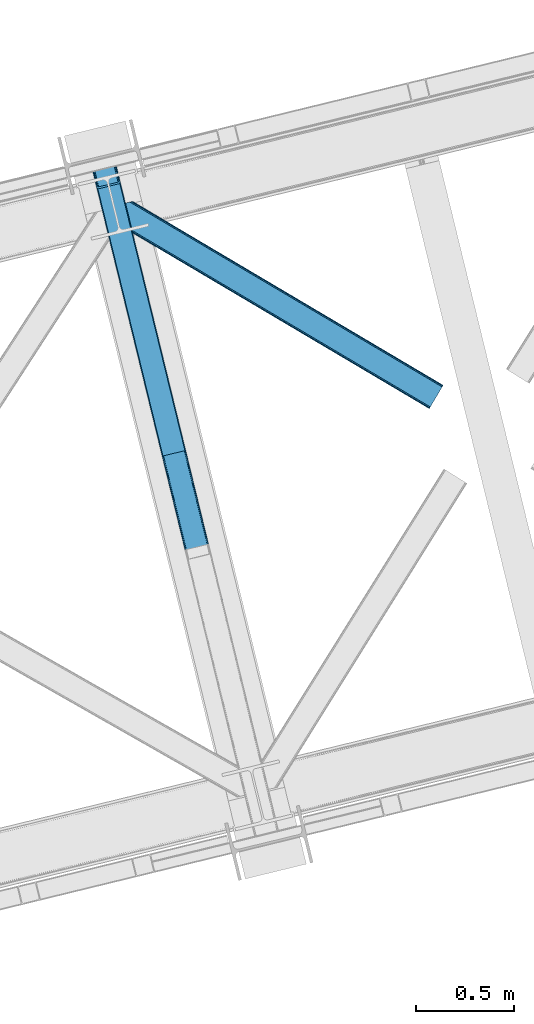
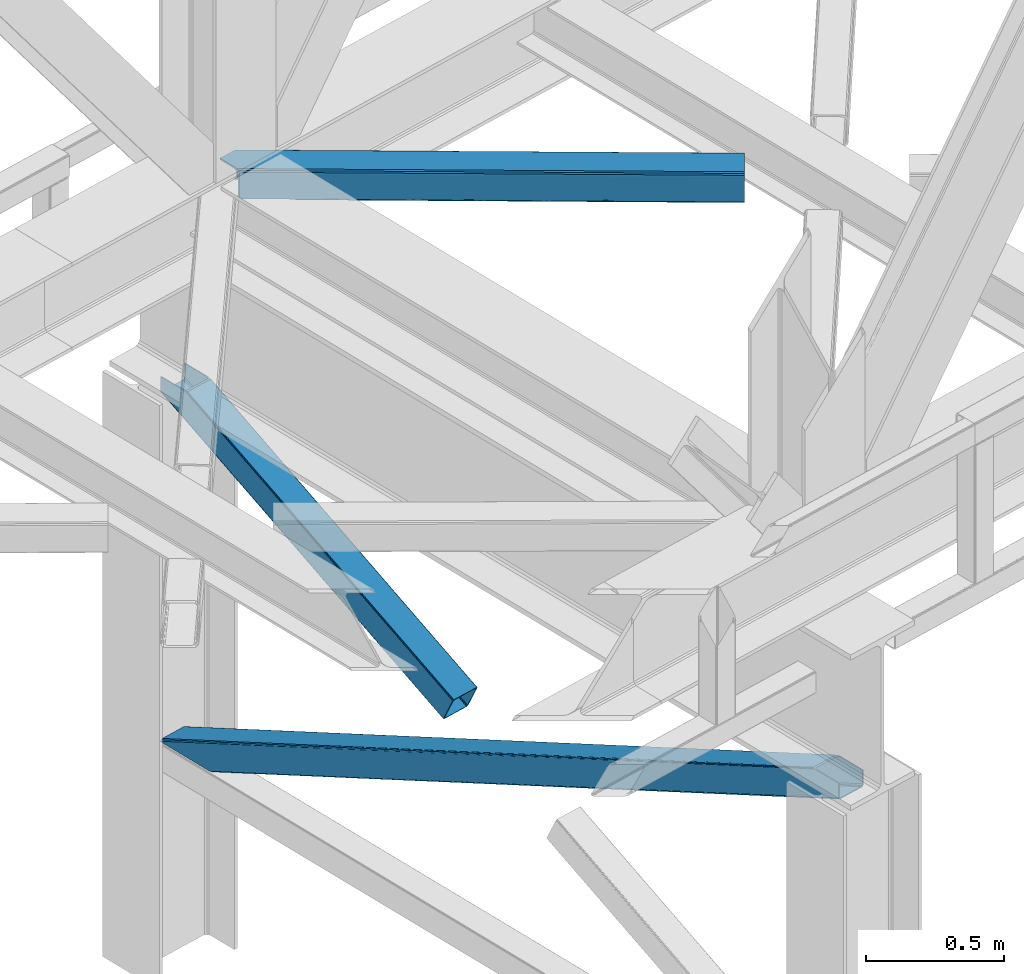
# One storey, part 57 of 92: 3 members.
"""IFC4 building model written with IfcOpenShell, lengths in millimetres."""

from ifc_helpers import new_model, entity, si_unit, converted_unit, derived_unit, direction, frame, origin, place, context, subcontext, project, spatial, triangles, polygons, type_object, element, save


model = new_model("IFC4")

# Units and contexts
model_context = context("Model", 3, precision=0.01, world=origin(), true_north=direction((6.12303176911189e-17, 1.0)))
plan_context = context("Plan", 3, precision=0.01, world=origin(), true_north=direction((6.12303176911189e-17, 1.0)))
body_context = subcontext(model_context, "Body", "Model", "MODEL_VIEW")
ifc_project = project(units=[si_unit("LENGTHUNIT", "METRE", prefix="MILLI"), si_unit("AREAUNIT", "SQUARE_METRE"), si_unit("VOLUMEUNIT", "CUBIC_METRE"), converted_unit("PLANEANGLEUNIT", "DEGREE", entity("IfcRatioMeasure", 0.0174532925199433), si_unit("PLANEANGLEUNIT", "RADIAN"), dimensions=[0, 0, 0, 0, 0, 0, 0]), si_unit("MASSUNIT", "GRAM", prefix="KILO"), derived_unit("MASSDENSITYUNIT", [(si_unit("MASSUNIT", "GRAM", prefix="KILO"), 1), (si_unit("LENGTHUNIT", "METRE"), -3)]), derived_unit("MOMENTOFINERTIAUNIT", [(si_unit("LENGTHUNIT", "METRE"), 4)]), si_unit("TIMEUNIT", "SECOND"), si_unit("FREQUENCYUNIT", "HERTZ"), si_unit("THERMODYNAMICTEMPERATUREUNIT", "DEGREE_CELSIUS"), derived_unit("THERMALTRANSMITTANCEUNIT", [(si_unit("MASSUNIT", "GRAM", prefix="KILO"), 1), (si_unit("THERMODYNAMICTEMPERATUREUNIT", "KELVIN"), -1), (si_unit("TIMEUNIT", "SECOND"), -3)]), derived_unit("VOLUMETRICFLOWRATEUNIT", [(si_unit("LENGTHUNIT", "METRE"), 3), (si_unit("TIMEUNIT", "SECOND"), -1)]), derived_unit("MASSFLOWRATEUNIT", [(si_unit("MASSUNIT", "GRAM", prefix="KILO"), 1), (si_unit("TIMEUNIT", "SECOND"), -1)]), derived_unit("ROTATIONALFREQUENCYUNIT", [(si_unit("TIMEUNIT", "SECOND"), -1)]), si_unit("ELECTRICCURRENTUNIT", "AMPERE"), si_unit("ELECTRICVOLTAGEUNIT", "VOLT"), si_unit("POWERUNIT", "WATT"), si_unit("FORCEUNIT", "NEWTON", prefix="KILO"), si_unit("ILLUMINANCEUNIT", "LUX"), si_unit("LUMINOUSFLUXUNIT", "LUMEN"), si_unit("LUMINOUSINTENSITYUNIT", "CANDELA"), derived_unit("USERDEFINED", [(si_unit("MASSUNIT", "GRAM", prefix="KILO"), -1), (si_unit("LENGTHUNIT", "METRE"), -2), (si_unit("TIMEUNIT", "SECOND"), 3), (si_unit("LUMINOUSFLUXUNIT", "LUMEN"), 1)]), derived_unit("LINEARVELOCITYUNIT", [(si_unit("LENGTHUNIT", "METRE"), 1), (si_unit("TIMEUNIT", "SECOND"), -1)]), si_unit("PRESSUREUNIT", "PASCAL"), derived_unit("USERDEFINED", [(si_unit("LENGTHUNIT", "METRE"), -2), (si_unit("MASSUNIT", "GRAM", prefix="KILO"), 1), (si_unit("TIMEUNIT", "SECOND"), -2)]), derived_unit("LINEARFORCEUNIT", [(si_unit("MASSUNIT", "GRAM", prefix="KILO"), 1), (si_unit("LENGTHUNIT", "METRE"), 1), (si_unit("TIMEUNIT", "SECOND"), -2), (si_unit("LENGTHUNIT", "METRE"), -1)]), derived_unit("PLANARFORCEUNIT", [(si_unit("MASSUNIT", "GRAM", prefix="KILO"), 1), (si_unit("LENGTHUNIT", "METRE"), 1), (si_unit("TIMEUNIT", "SECOND"), -2), (si_unit("LENGTHUNIT", "METRE"), -2)])], contexts=[model_context, plan_context])

# Site, building, storey
site_placement = place(None, origin())
site = spatial("IfcSite", under=ifc_project, at=site_placement, CompositionType="ELEMENT")
building_placement = place(site_placement, origin())
building = spatial("IfcBuilding", under=site, at=building_placement, CompositionType="ELEMENT")
storey_placement = place(building_placement, frame((0.0, 0.0, 15900.0)))
storey = spatial("IfcBuildingStorey", under=building, at=storey_placement, Name="05", CompositionType="ELEMENT", Elevation=15900.0)

# Members
member_type_1 = type_object("IfcMemberType", PredefinedType="BRACE")
member_1_placement = place(storey_placement, frame((-30279.23, 12158.54, 1820.91)))
element("IfcMember", 1, at=member_1_placement, inside=storey, type_object=member_type_1, ObjectType="Steel Vertical Brace", PredefinedType="BRACE", context=body_context, shape_type="Tessellation", body=[
    polygons([(29.8135191782847, 1388.61826467864, 771.091297096984), (32.1113287327985, 1381.7631169139, 771.091297096991), (368.111452939622, 3.36089743274636, 105.060837153753), (367.211709770158, 4.48063717440627, 102.289544138114), (35.2425975620341, 1376.24004026086, 771.091297096982), (370.057498317433, 2.70006492288447, 107.410225929579), (38.7306183717297, 1372.88987307312, 771.091297096984), (372.753578135712, 2.59874540397378, 108.980037321763), (42.0443716126254, 1372.22264793569, 771.091297096984), (375.789238682203, 3.07236385431457, 109.531281776207), (140.171129484908, 1396.14208332771, 771.091297096984), (473.91599655449, 26.9917992463367, 109.531281776209), (142.806126265313, 1398.25937921937, 771.091297096991), (476.829086029299, 27.9682515502241, 108.980037321767), (144.361212211709, 1402.83885703392, 771.091297096989), (479.176112967103, 29.2988816959484, 107.410225929583), (144.599639585688, 1409.18333278718, 771.091297096997), (480.599763792512, 30.7811133060244, 105.060837153757), (143.485109980843, 1416.32691755851, 771.091297096984), (480.883300572716, 32.1892900542756, 102.289544138114), (149.600536198007, 1408.12910918704, 771.091297096982), (121.444007267685, 1523.63806044727, 771.091297096982), (117.557799035124, 1522.69075607531, 771.09129709698), (3.88620823256572, 1494.98210319544, 771.091297096982), (4.33146851719357e-12, 1494.03479882348, 771.091297096982), (28.1565289303171, 1378.52584756325, 771.091297096982), (30.4543384848396, 1371.67069979849, 771.091297096982), (33.5856073140622, 1366.14762314545, 771.091297096982), (37.0736281237621, 1362.79745595771, 771.091297096984), (40.3873813646535, 1362.13023082029, 771.09129709698), (146.286555702076, 1387.94427495624, 771.09129709698), (148.921552482481, 1390.06157084789, 771.091297096984), (150.476638428877, 1394.64104866244, 771.09129709698), (150.715065802839, 1400.9855244157, 771.09129709698), (359.725704690142, 52.0811507006333, 4.33146851719357e-12), (465.62487902756, 77.8951948365822, 2.16573425859679e-12), (468.660539574047, 78.3688132869209, 0.551244454446396), (471.356619392343, 78.2674937680102, 2.12105584662818), (473.302664770137, 77.6066612581461, 4.4704446224671), (474.202407939605, 76.4869215164862, 7.24173763810153), (485.172065028735, 31.4851533942308, 105.910412957166), (484.888528248512, 30.0769766459796, 108.681705972796), (483.464877423122, 28.5947450359037, 111.031094748631), (481.117850485317, 27.264114890175, 112.600906140819), (478.204761010512, 26.2876625862897, 113.152150595261), (372.305586673086, 0.473618450342957, 113.152150595257), (369.269926126603, 2.16573425859679e-12, 112.600906140819), (366.573846308307, 0.101319518910685, 111.031094748635), (364.627800930509, 0.76215202877691, 108.681705972796), (363.728057761041, 1.88189177043682, 105.910412957166), (352.758400671911, 46.8836598926922, 7.24173763810153), (353.041937452142, 48.2918366409434, 4.4704446224671), (354.465588277524, 49.7740682510194, 2.12105584662385), (356.812615215332, 51.1046983967459, 0.551244454448562), (470.718755930487, 73.8881761125124, 10.8626064571491), (469.819012761023, 75.0079158541745, 8.09131344151462), (467.872967383238, 75.6687483640451, 5.74192466567137), (465.176887564938, 75.7700678829471, 4.17211327349608), (462.141227018446, 75.2964494326106, 3.62086881905185), (364.01446914616, 51.3770140405885, 3.62086881905185), (361.101379671355, 50.4005617367011, 4.17211327349392), (358.754352733542, 49.0699315909703, 5.7419246656757), (357.330701908156, 47.5876999808965, 8.09131344151245), (357.047165127938, 46.1795232326431, 10.8626064571491), (3.88620823256139, 1494.98210319544, 710.909831470177), (117.557799035124, 1522.69075607531, 710.909831470177), (11.6586246977015, 1496.87671193937, 702.072173549059), (8.91066050334255, 1496.2068665941, 703.366418586696), (6.1626963089966, 1495.53702124884, 704.660663624352), (5.02445227078549, 1495.25956222214, 707.785247547262), (116.4195549969, 1522.41329704861, 707.785247547264), (115.281310958689, 1522.13583802191, 704.660663624352), (112.533346764338, 1521.46599267665, 703.3664185867), (109.785382569988, 1520.79614733139, 702.072173549057), (120.30576322947, 1523.36060142057, 703.366418586702), (119.167519191254, 1523.08314239387, 700.241834663787), (116.419554996908, 1522.41329704861, 698.94758962614), (113.671590802554, 1521.74345170335, 697.653344588497), (7.77241646513577, 1495.9294075674, 697.653344588497), (5.02445227078549, 1495.25956222214, 698.94758962614), (2.27648807643521, 1494.58971687688, 700.241834663785), (1.13824403821544, 1494.31225785018, 703.366418586702), (4.33146851719357e-12, 1494.03479882348, 706.491002509615), (121.44400726769, 1523.63806044727, 706.491002509615)], [[[1, 2, 3, 4]], [[2, 5, 6, 3]], [[5, 7, 8, 6]], [[7, 9, 10, 8]], [[9, 11, 12, 10]], [[11, 13, 14, 12]], [[13, 15, 16, 14]], [[15, 17, 18, 16]], [[17, 19, 20, 18]], [[21, 22, 23, 19, 17, 15, 13, 11, 9, 7, 5, 2, 1, 24, 25, 26, 27, 28, 29, 30, 31, 32, 33, 34]], [[35, 36, 37, 38, 39, 40, 41, 42, 43, 44, 45, 46, 47, 48, 49, 50, 51, 52, 53, 54], [55, 56, 57, 58, 59, 60, 61, 62, 63, 64, 4, 3, 6, 8, 10, 12, 14, 16, 18, 20]], [[24, 1, 4, 64, 65]], [[19, 23, 66, 55, 20]], [[61, 67, 68]], [[62, 68, 69]], [[63, 69, 70]], [[64, 70, 65]], [[70, 64, 63]], [[69, 63, 62]], [[68, 62, 61]], [[67, 61, 60]], [[55, 71, 56]], [[56, 72, 57]], [[57, 73, 58]], [[58, 74, 59]], [[74, 58, 73]], [[73, 57, 72]], [[72, 56, 71]], [[71, 55, 66]], [[74, 67, 60, 59]], [[75, 76, 77, 78, 79, 80, 81, 82, 83, 25, 24, 65, 70, 69, 68, 67, 74, 73, 72, 71, 66, 23, 22, 84]], [[30, 29, 47, 46]], [[29, 28, 48, 47]], [[28, 27, 49, 48]], [[27, 26, 50, 49]], [[45, 31, 30, 46]], [[21, 34, 42, 41]], [[34, 33, 43, 42]], [[33, 32, 44, 43]], [[32, 31, 45, 44]], [[50, 26, 25, 83, 51]], [[84, 22, 21, 41, 40]], [[51, 82, 52]], [[52, 81, 53]], [[53, 80, 54]], [[54, 79, 35]], [[79, 54, 80]], [[80, 53, 81]], [[81, 52, 82]], [[82, 51, 83]], [[37, 78, 77]], [[38, 77, 76]], [[39, 76, 75]], [[40, 75, 84]], [[75, 40, 39]], [[76, 39, 38]], [[77, 38, 37]], [[78, 37, 36]], [[35, 79, 78, 36]]], closed=True),
])
member_type_2 = type_object("IfcMemberType", PredefinedType="BRACE")
member_2_placement = place(storey_placement, frame((-30279.22, 10185.59, 970.5)))
element("IfcMember", 2, at=member_2_placement, inside=storey, type_object=member_type_2, ObjectType="Steel Vertical Brace", PredefinedType="BRACE", context=body_context, shape_type="Tessellation", body=[
    triangles([(177.814727783203, 3231.5446105957, 0.0), (958.785662841798, 27.7087738037098, 1548.06132202148), (852.885150146485, 1.89407043456958, 1548.06132202148), (71.9165405273452, 3205.72990722656, 0.0), (961.532006835936, 28.3785003662106, 1549.35542907715), (964.278350830078, 29.0482269287095, 1550.65069885254), (180.449450683594, 3233.66076049805, 0.0), (965.417816162109, 29.3249542236317, 1553.77492675781), (182.005169677734, 3238.24071350098, 0.0), (966.557281494141, 29.6028442382813, 1556.89915466309), (182.242364501952, 3244.58567504883, 0.0), (181.128479003906, 3251.72942504883, 0.0), (845.113531494142, 0.0, 1556.89915466309), (59.6847290039077, 3222.12541809082, 0.0), (61.9845886230469, 3215.27118530273, 0.0), (846.250671386719, 0.27672729492042, 1553.77492675781), (65.1146301269546, 3209.74710388183, 0.0), (847.387811279295, 0.554617309569949, 1550.65069885254), (68.6004638671875, 3206.39730834961, 0.0), (850.138806152343, 1.22434387206886, 1549.35542907715), (121.443749999999, 3496.58657226562, 2.0998718261726), (938.400860595702, 145.112072753906, 1621.4998626709), (121.443749999999, 3496.58657226562, 0.0), (966.557281494141, 29.6028442382813, 1621.4998626709), (0.0, 3466.98372802734, 2.0998718261726), (816.957110595704, 115.509228515624, 1621.4998626709), (0.0, 3466.98372802734, 0.0), (845.113531494142, 0.0, 1621.4998626709), (116.418475341798, 3495.36106567383, 9.64359741210865), (113.669805908205, 3494.69250183105, 10.9377044677749), (926.169049072265, 161.507583618164, 1621.4998626709), (119.164819335936, 3496.03079223633, 8.34949035644604), (929.482800292968, 160.840182495116, 1621.4998626709), (120.304284667967, 3496.30868225098, 5.22409973144386), (932.970959472656, 157.490386962891, 1621.4998626709), (936.101000976563, 151.967468261719, 1621.4998626709), (7.77161865234302, 3468.87779846191, 10.9377044677749), (820.270861816407, 135.694042968749, 1621.4998626709), (815.843225097655, 122.652978515624, 1621.4998626709), (1.13481445312573, 3467.26045532226, 5.22409973144386), (816.078094482422, 128.996777343749, 1621.4998626709), (2.27427978515698, 3467.53834533691, 8.34949035644604), (817.633813476561, 133.575567626953, 1621.4998626709), (5.02294921875, 3468.20807189941, 9.64359741210865), (4.15556030273365, 3467.99645690918, 0.0), (4.76482543945167, 3468.14528503418, 0.782510375975107), (6.74609985351708, 3468.6278137207, 3.34281921386719), (117.283538818359, 3495.57268066406, 0.0), (116.797521972658, 3495.45408325195, 0.95459289550854), (115.279010009766, 3495.08433837891, 3.92999267578125), (8.68086547851635, 3469.09987792969, 5.84615478515479), (109.783996582031, 3493.74488525391, 6.51936950683739), (11.6574279785164, 3469.82541503906, 6.51936950683739), (112.532666015624, 3494.41461181641, 5.22409973144386), (924.513336181641, 151.415176391602, 1621.4998626709), (826.384442138671, 127.495706176756, 1621.4998626709), (118.725311279297, 3490.84157409668, 0.0), (936.742822265624, 135.019665527343, 1621.4998626709), (934.445288085939, 141.875061035156, 1621.4998626709), (931.312921142577, 147.397979736328, 1621.4998626709), (927.824761962889, 150.747775268554, 1621.4998626709), (962.671472167967, 28.6552276611328, 1621.4998626709), (822.194000244141, 120.798440551756, 1621.4998626709), (823.74971923828, 125.378393554687, 1621.4998626709), (823.070690917968, 107.310891723631, 1621.4998626709), (821.956805419923, 114.454641723632, 1621.4998626709), (848.999340820312, 0.947616577148438, 1621.4998626709), (5.05550537109229, 3463.13280029297, 0.0), (175.014898681642, 3259.92659912109, 0.0), (962.671472167967, 28.6552276611328, 1561.31865234375), (61.3427673339829, 3232.21782531738, 0.0), (848.999340820312, 0.947616577148438, 1561.31865234375), (66.7703430175789, 3219.8395111084, 0.0), (63.6403015136711, 3225.3635925293, 0.0), (70.2585021972664, 3216.48971557617, 0.0), (73.5722534179695, 3215.82231445312, 0.0), (175.889263916015, 3246.43905029297, 0.0), (176.128784179688, 3252.78284912109, 0.0), (174.333544921876, 3241.85909729004, 0.0), (171.701147460939, 3239.74178466797, 0.0), (954.897528076173, 26.7611572265614, 1552.48081970215), (957.646197509766, 27.4308837890621, 1553.77492675781), (960.392541503905, 28.100610351561, 1555.06903381348), (856.770959472655, 2.84168701171802, 1552.48081970215), (854.024615478516, 2.17196044921729, 1553.77492675781), (851.273620605469, 1.50223388671839, 1555.06903381348), (961.532006835936, 28.3785003662106, 1558.19326171875), (850.138806152343, 1.22434387206886, 1558.19326171875)], [[1, 2, 3], [3, 4, 1], [5, 2, 1], [6, 5, 7], [8, 6, 9], [10, 8, 11], [11, 12, 10], [9, 11, 8], [7, 9, 6], [1, 7, 5], [13, 14, 15], [16, 15, 17], [18, 17, 19], [20, 19, 4], [4, 3, 20], [19, 20, 18], [17, 18, 16], [15, 16, 13], [12, 21, 22], [12, 23, 21], [22, 10, 12], [24, 10, 22], [25, 14, 26], [14, 25, 27], [13, 26, 14], [28, 26, 13], [29, 30, 31], [32, 29, 33], [34, 32, 35], [21, 34, 36], [36, 22, 21], [35, 36, 34], [33, 35, 32], [31, 33, 29], [31, 30, 37], [37, 38, 31], [25, 26, 39], [40, 39, 41], [42, 41, 43], [44, 43, 38], [38, 37, 44], [43, 44, 42], [41, 42, 40], [39, 40, 25], [45, 25, 46], [45, 27, 25], [46, 40, 47], [40, 42, 47], [25, 40, 46], [48, 21, 23], [21, 48, 49], [49, 34, 21], [34, 49, 50], [47, 44, 51], [37, 30, 52], [53, 51, 37], [52, 53, 37], [51, 44, 37], [42, 44, 47], [30, 54, 52], [29, 50, 54], [50, 32, 34], [50, 29, 32], [30, 29, 54], [52, 55, 56], [56, 53, 52], [57, 58, 59], [49, 48, 57], [49, 59, 60], [50, 60, 61], [54, 61, 55], [55, 52, 54], [61, 54, 50], [60, 50, 49], [59, 49, 57], [61, 60, 36], [35, 61, 36], [61, 35, 33], [55, 31, 38], [33, 55, 61], [31, 55, 33], [60, 22, 36], [24, 58, 62], [24, 22, 58], [60, 59, 22], [59, 58, 22], [39, 63, 64], [38, 56, 55], [56, 43, 64], [43, 56, 38], [64, 41, 39], [41, 64, 43], [26, 63, 39], [65, 66, 26], [66, 63, 26], [65, 28, 67], [26, 28, 65], [47, 51, 64], [46, 47, 63], [68, 46, 66], [66, 65, 68], [68, 45, 46], [63, 66, 46], [64, 63, 47], [53, 56, 51], [64, 51, 56], [58, 69, 70], [58, 57, 69], [70, 62, 58], [71, 65, 72], [65, 71, 68], [67, 72, 65], [73, 15, 14], [27, 68, 71], [68, 27, 45], [14, 71, 74], [71, 14, 27], [74, 73, 14], [75, 15, 73], [17, 75, 19], [17, 15, 75], [19, 76, 4], [4, 76, 1], [75, 76, 19], [12, 11, 77], [78, 69, 12], [77, 78, 12], [23, 57, 48], [69, 23, 12], [57, 23, 69], [11, 79, 77], [80, 7, 1], [80, 1, 76], [80, 79, 7], [79, 9, 7], [79, 11, 9], [81, 3, 2], [2, 5, 82], [6, 83, 5], [83, 82, 5], [2, 82, 81], [83, 6, 8], [84, 3, 81], [20, 85, 86], [20, 3, 85], [86, 18, 20], [18, 86, 16], [84, 85, 3], [87, 10, 70], [8, 87, 83], [10, 87, 8], [24, 70, 10], [24, 62, 70], [16, 88, 13], [13, 88, 72], [86, 88, 16], [72, 28, 13], [28, 72, 67], [81, 80, 76], [76, 84, 81], [70, 69, 78], [87, 78, 77], [83, 77, 79], [82, 79, 80], [80, 81, 82], [79, 82, 83], [77, 83, 87], [78, 87, 70], [85, 84, 76], [86, 85, 75], [88, 86, 73], [72, 88, 74], [74, 71, 72], [73, 74, 88], [75, 73, 86], [76, 75, 85]]),
])
member_type_3 = type_object("IfcMemberType", PredefinedType="BRACE")
member_3_placement = place(storey_placement, frame((-30155.6, 12399.07, 3510.0)))
element("IfcMember", 3, at=member_3_placement, inside=storey, type_object=member_type_3, ObjectType="Steel Horizontal Brace", PredefinedType="BRACE", context=body_context, shape_type="Tessellation", body=[
    triangles([(1674.92102050781, 120.470553588868, 122.500662231447), (1674.92102050781, 120.470553588868, 17.5000946044929), (91.5037170410142, 1057.89356689453, 17.5000946044929), (91.5037170410142, 1057.89356689453, 122.500662231447), (1666.00761108398, 105.412170410156, 139.999594116212), (1669.41903076172, 111.174609375001, 138.667117309571), (76.4813781738267, 1054.23099975586, 138.667117309571), (67.1726440429666, 1051.96137084961, 139.999594116212), (1672.31187744141, 116.060357666016, 134.874325561526), (84.376245117186, 1056.15530090332, 134.874325561526), (1674.24431762695, 119.325274658204, 129.197927856447), (89.6526672363252, 1057.4412689209, 129.197927856447), (18.7686218261697, 958.594976806642, 139.999594116212), (1612.51552734375, 15.059545898439, 139.999594116212), (0.0, 1035.58795166016, 139.999594116212), (1603.59979248047, 0.0, 122.500662231447), (1604.27882080078, 1.14644165039135, 129.197927856447), (24.5636169433565, 934.827822875977, 122.500662231447), (24.1217834472627, 936.637014770509, 129.197927856447), (1606.21126098633, 4.41135864257922, 134.874325561526), (22.8660461425752, 941.789025878907, 134.874325561526), (1609.10410766601, 9.29594421386719, 138.667117309571), (20.9870910644531, 949.499020385743, 138.667117309571), (1603.59979248047, 0.0, 17.5000946044929), (24.5636169433565, 934.827822875977, 17.5000946044929), (1674.24431762695, 119.325274658204, 10.8028289794929), (89.5643005371094, 1057.42033996582, 10.8167816162131), (162.741229248044, 1014.02182617188, 10.5005218505867), (1672.31187744141, 116.060357666016, 5.12526855468968), (165.157360839843, 1008.33263854981, 5.12526855468968), (164.099285888671, 1012.66493225098, 9.50058288574292), (163.771398925779, 1012.99281921387, 9.74126586914281), (163.420257568359, 1013.34396057129, 10.0005523681648), (163.066790771481, 1013.69510192871, 10.2586761474631), (89.4712829589844, 1057.39708557129, 10.5005218505867), (1669.41903076172, 111.174609375001, 1.33247680664135), (167.036315917969, 1000.62264404297, 1.33247680664135), (1666.00761108398, 105.412170410156, 0.0), (169.252459716794, 991.527850341798, 0.0), (1612.51552734375, 15.059545898439, 0.0), (204.013128662107, 848.927252197267, 0.0), (166.892138671872, 996.992633056641, 10.5005218505867), (72.0374633789033, 1053.14850769043, 10.5005218505867), (168.587384033202, 994.262567138672, 9.50058288574292), (168.16880493164, 994.934619140626, 9.74591674804833), (167.738598632812, 995.627600097658, 10.0005523681648), (167.306066894529, 996.319418334962, 10.2540252685576), (1668.74465332031, 110.037469482422, 12.1260040283232), (1670.67709350586, 113.301223754883, 17.8035644531265), (79.9183776855461, 1055.06932067871, 17.8035644531265), (1665.85180664063, 105.151721191407, 8.3320495605476), (169.401287841796, 990.919747924805, 8.81690368652562), (74.1164062499993, 1053.65429077148, 12.4271484375022), (171.570922851563, 982.021453857422, 6.99957275390625), (1662.44038696289, 99.388119506837, 6.99957275390625), (1671.35612182617, 114.447665405274, 24.4996673583992), (81.771752929686, 1055.52045593262, 24.4996673583992), (1671.35612182617, 114.447665405274, 115.501089477541), (81.771752929686, 1055.52045593262, 115.501089477541), (74.6442810058579, 1053.78335266113, 127.87475280762), (66.7494140624985, 1051.85905151367, 131.667544555665), (79.9183776855461, 1055.06932067871, 122.196029663086), (57.4383544921875, 1049.58942260742, 133.000021362306), (0.0, 1035.58795166016, 133.000021362306), (1670.67709350586, 113.301223754883, 122.196029663086), (1668.74465332031, 110.037469482422, 127.87475280762), (1665.85180664063, 105.151721191407, 131.667544555665), (1662.44038696289, 99.388119506837, 133.000021362306), (16.4524841308594, 968.101373291016, 133.000021362306), (1616.08042602539, 21.0824340820327, 133.000021362306), (1616.08042602539, 21.0824340820327, 6.99957275390625), (201.696990966797, 858.433648681641, 6.99957275390625), (1609.77848510742, 10.434246826173, 127.87475280762), (1612.66900634766, 15.3199951171882, 131.667544555665), (1607.16701660156, 6.02405090332104, 115.501089477541), (1607.84371948242, 7.1693298339851, 122.196029663086), (1609.10410766601, 9.29594421386719, 1.33247680664135), (1609.77848510742, 10.434246826173, 12.1260040283232), (1606.21126098633, 4.41135864257922, 5.12526855468968), (1612.66900634766, 15.3199951171882, 8.3320495605476), (1604.27882080078, 1.14644165039135, 10.8028289794929), (1607.16701660156, 6.02405090332104, 24.4996673583992), (1607.84371948242, 7.1693298339851, 17.8035644531265), (18.6686279296846, 959.006579589844, 131.667544555665), (20.5475830078103, 951.295422363282, 127.87475280762), (21.8033203124978, 946.143411254883, 122.196029663086), (22.2451538085916, 944.334219360353, 115.501089477541), (22.2451538085916, 944.334219360353, 24.4996673583992), (21.7823913574211, 946.22945251465, 17.8163543701194), (21.7614624023408, 946.318981933595, 17.5000946044929), (203.864300537109, 849.535354614258, 8.81690368652562), (206.229272460936, 839.832458496094, 1.33247680664135), (204.680529785153, 846.192535400391, 9.50058288574292), (208.110552978513, 832.122463989259, 5.12526855468968), (209.166302490234, 827.789007568361, 9.50058288574292), (204.685180664063, 844.928659057618, 10.2075164794951), (204.327062988279, 844.907730102539, 10.3540191650391), (203.968945312499, 844.885638427735, 10.5005218505867), (27.0146301269524, 947.468911743164, 12.1260040283232), (28.3494323730447, 948.857199096681, 10.5005218505867), (204.682855224608, 845.561178588869, 9.85404968261719), (32.1398986816384, 931.964044189453, 10.8179443359404), (209.136071777342, 827.584368896485, 9.88311767578125), (208.119854736327, 827.857608032227, 10.5005218505867), (208.803533935545, 827.672735595705, 10.0842681884787), (32.5003417968728, 931.828005981446, 10.5005218505867)], [[1, 2, 3], [3, 4, 1], [5, 6, 7], [7, 8, 5], [6, 9, 10], [10, 7, 6], [9, 11, 12], [12, 10, 9], [11, 1, 4], [4, 12, 11], [5, 13, 14], [13, 5, 8], [15, 13, 8], [16, 17, 18], [19, 18, 17], [17, 20, 19], [21, 19, 20], [20, 22, 21], [23, 21, 22], [22, 14, 23], [13, 23, 14], [24, 16, 18], [18, 25, 24], [26, 27, 3], [27, 26, 28], [26, 29, 30], [30, 31, 26], [26, 32, 33], [32, 26, 31], [26, 34, 28], [34, 26, 33], [28, 35, 27], [29, 36, 37], [37, 30, 29], [36, 38, 39], [39, 37, 36], [3, 2, 26], [38, 40, 41], [41, 39, 38], [28, 42, 35], [43, 35, 42], [31, 44, 45], [45, 32, 31], [32, 45, 46], [46, 33, 32], [33, 46, 47], [47, 34, 33], [34, 47, 42], [42, 28, 34], [48, 49, 50], [45, 51, 46], [45, 44, 51], [42, 47, 51], [47, 46, 51], [44, 52, 51], [48, 53, 42], [42, 51, 48], [53, 43, 42], [51, 52, 54], [54, 55, 51], [50, 53, 48], [49, 56, 57], [57, 50, 49], [56, 58, 57], [59, 57, 58], [60, 61, 7], [10, 60, 7], [10, 12, 62], [60, 10, 62], [62, 12, 4], [61, 8, 7], [15, 63, 64], [15, 8, 63], [61, 63, 8], [62, 4, 59], [57, 3, 50], [4, 57, 59], [3, 27, 50], [4, 3, 57], [35, 50, 27], [35, 53, 50], [35, 43, 53], [58, 65, 59], [62, 59, 65], [65, 66, 62], [60, 62, 66], [66, 67, 60], [61, 60, 67], [67, 68, 61], [63, 61, 68], [68, 69, 63], [68, 70, 69], [69, 64, 63], [71, 55, 72], [54, 72, 55], [11, 66, 65], [58, 2, 1], [11, 65, 1], [11, 9, 66], [65, 58, 1], [66, 9, 6], [68, 5, 14], [5, 67, 6], [67, 5, 68], [67, 66, 6], [26, 48, 29], [56, 2, 58], [2, 49, 26], [49, 2, 56], [26, 49, 48], [38, 55, 40], [36, 29, 48], [48, 51, 36], [51, 55, 38], [38, 36, 51], [73, 22, 20], [14, 70, 68], [14, 74, 70], [74, 14, 22], [73, 74, 22], [75, 16, 24], [17, 76, 73], [20, 17, 73], [76, 17, 16], [75, 76, 16], [77, 78, 79], [40, 55, 71], [71, 80, 40], [80, 78, 77], [77, 40, 80], [81, 79, 78], [24, 82, 75], [83, 24, 81], [24, 83, 82], [83, 81, 78], [70, 74, 84], [84, 69, 70], [74, 73, 85], [85, 84, 74], [73, 76, 86], [86, 85, 73], [76, 75, 87], [87, 86, 76], [75, 82, 87], [88, 87, 82], [86, 87, 18], [18, 19, 86], [21, 86, 19], [86, 21, 85], [18, 88, 25], [89, 90, 25], [25, 88, 89], [87, 88, 18], [84, 23, 13], [15, 69, 13], [64, 69, 15], [84, 85, 23], [23, 85, 21], [69, 84, 13], [44, 30, 37], [39, 44, 37], [54, 52, 39], [54, 39, 72], [30, 44, 31], [39, 52, 44], [72, 41, 91], [41, 92, 93], [41, 72, 39], [94, 93, 92], [41, 93, 91], [94, 95, 93], [83, 89, 88], [71, 72, 91], [78, 96, 97], [97, 98, 78], [98, 99, 78], [98, 100, 99], [80, 91, 93], [93, 78, 80], [78, 93, 101], [101, 96, 78], [83, 78, 99], [99, 90, 83], [90, 89, 83], [91, 80, 71], [88, 82, 83], [24, 25, 102], [79, 103, 95], [81, 102, 104], [104, 79, 81], [104, 105, 79], [95, 94, 79], [40, 77, 92], [92, 41, 40], [77, 79, 94], [94, 92, 77], [106, 81, 24], [99, 106, 25], [99, 100, 106], [25, 90, 99], [98, 104, 106], [106, 100, 98]]),
])

save(model, "model.ifc")
